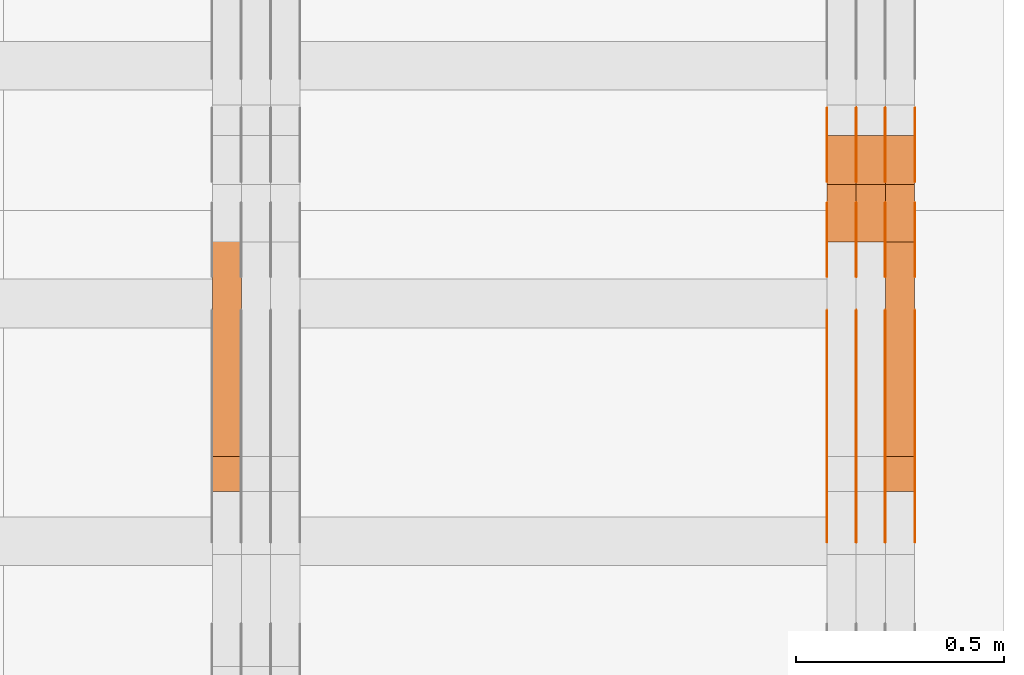
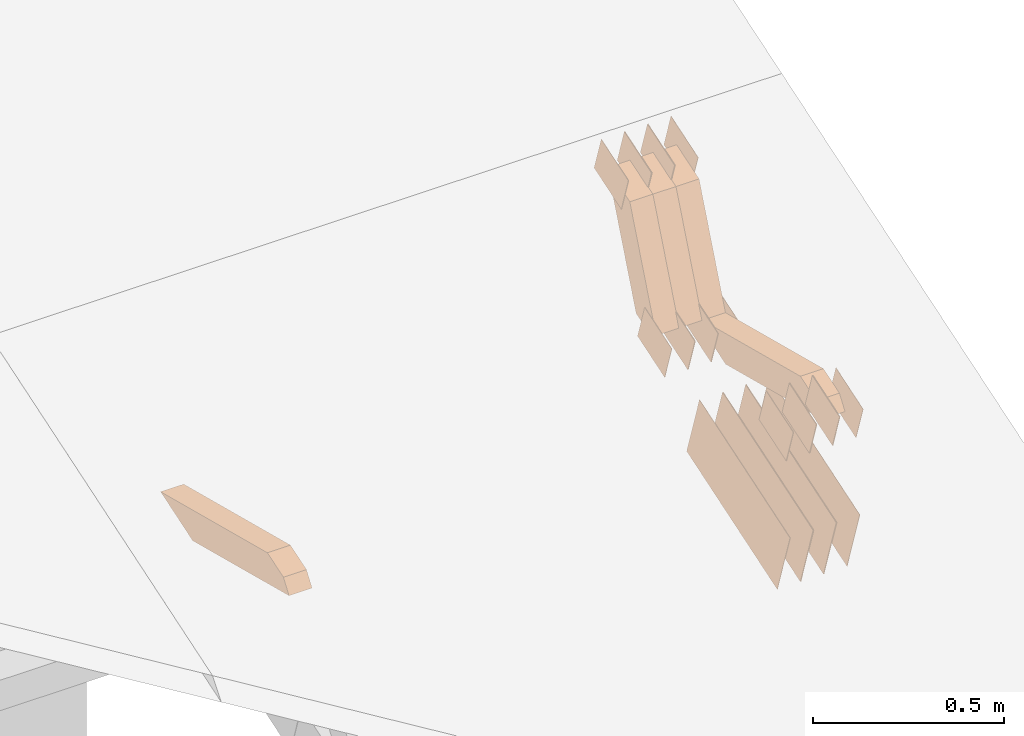
# One storey, part 315 of 385: 29 proxies.
"""IFC2X3 building model written with IfcOpenShell, lengths in millimetres."""

import ifcopenshell
import ifcopenshell.guid

model = None  # the IFC model being written
_history = None  # IfcOwnerHistory: only IFC2X3 demands one
_inside = {}  # id of a spatial element -> (the spatial element, [elements in it])
_under = {}  # id of a project, library or spatial element -> (it, [spatial elements below it])
_declared = {}  # id of a project -> (the project, [libraries it declares])
_typed = {}  # id of a type object -> (the type object, [elements of that type])
_made_of = {}  # id of a material, layer set ... -> (it, [elements and type objects made of it])


def new_model(schema):
    """Start an empty IFC model of exactly this schema.

    Asked for "IFC4X3", IfcOpenShell would pick the latest addendum, in which some entities
    have other attributes; the version numbers below select the first issue.
    IFC2X3 requires an IfcOwnerHistory on every rooted entity: one is made here for all.
    """
    global model, _history
    if schema == "IFC4X3":
        model = ifcopenshell.file(schema_version=(4, 3, 0, 0))
    else:
        model = ifcopenshell.file(schema=schema)
    _inside.clear()
    _under.clear()
    _declared.clear()
    _typed.clear()
    _made_of.clear()
    _history = None
    if model.schema == "IFC2X3":
        org = make("IfcOrganization", Name="unknown")
        user = make(
            "IfcPersonAndOrganization",
            ThePerson=make("IfcPerson", FamilyName="unknown"),
            TheOrganization=org,
        )
        app = make(
            "IfcApplication",
            ApplicationDeveloper=org,
            Version="unknown",
            ApplicationFullName="unknown",
            ApplicationIdentifier="unknown",
        )
        _history = make(
            "IfcOwnerHistory",
            OwningUser=user,
            OwningApplication=app,
            ChangeAction="ADDED",
            CreationDate=0,
        )
    return model


def make(cls, **values):
    """One entity of the class cls with the attributes given. An attribute that is None is left unset."""
    return model.create_entity(
        cls, **{name: value for name, value in values.items() if value is not None}
    )


def entity(cls, *values):
    """Any entity or typed value of the class cls, its attributes in the order of the schema. None: left unset."""
    e = model.create_entity(cls)
    for i, value in enumerate(values):
        if value is not None:
            e[i] = value
    return e


def rooted(cls, **values):
    """An entity with a GlobalId (a new one), such as an element, a storey or a relation."""
    return make(cls, GlobalId=ifcopenshell.guid.new(), OwnerHistory=_history, **values)


def si_unit(unit_type, name, prefix=None):
    """IfcSIUnit, for example si_unit("LENGTHUNIT", "METRE", prefix="MILLI")."""
    return make("IfcSIUnit", UnitType=unit_type, Prefix=prefix, Name=name)


def converted_unit(unit_type, name, factor, base, dimensions=None, offset=None):
    """IfcConversionBasedUnit, such as the inch: factor (a typed value) times the base unit."""
    return make(
        "IfcConversionBasedUnit"
        if offset is None
        else "IfcConversionBasedUnitWithOffset",
        ConversionOffset=offset,
        Dimensions=None
        if dimensions is None
        else entity("IfcDimensionalExponents", *dimensions),
        UnitType=unit_type,
        Name=name,
        ConversionFactor=make(
            "IfcMeasureWithUnit", ValueComponent=factor, UnitComponent=base
        ),
    )


def derived_unit(unit_type, elements):
    """IfcDerivedUnit: a product of units, each with its exponent."""
    return make(
        "IfcDerivedUnit",
        Elements=[
            make("IfcDerivedUnitElement", Unit=unit, Exponent=power)
            for unit, power in elements
        ],
        UnitType=unit_type,
    )


def assignment(units):
    """IfcUnitAssignment: the units of a project."""
    return None if units is None else make("IfcUnitAssignment", Units=units)


def point(xyz):
    """IfcCartesianPoint."""
    return None if xyz is None else make("IfcCartesianPoint", Coordinates=xyz)


def direction(xyz):
    """IfcDirection."""
    return None if xyz is None else make("IfcDirection", DirectionRatios=xyz)


def frame(location, z_axis=None, x_axis=None):
    """IfcAxis2Placement3D, a coordinate frame: its origin and axes. An axis left out is left unset."""
    return make(
        "IfcAxis2Placement3D",
        Location=point(location),
        Axis=direction(z_axis),
        RefDirection=direction(x_axis),
    )


def origin():
    """The frame at (0, 0, 0) with its axes left unset."""
    return frame((0.0, 0.0, 0.0))


def place(relative_to, where):
    """IfcLocalPlacement: puts the frame where relative to a parent placement (None: the world)."""
    return make(
        "IfcLocalPlacement", PlacementRelTo=relative_to, RelativePlacement=where
    )


def context(
    kind, dimensions, precision=None, world=None, true_north=None, identifier=None
):
    """IfcGeometricRepresentationContext, for example the 3D "Model" context."""
    return make(
        "IfcGeometricRepresentationContext",
        ContextIdentifier=identifier,
        ContextType=kind,
        CoordinateSpaceDimension=dimensions,
        Precision=precision,
        WorldCoordinateSystem=world,
        TrueNorth=true_north,
    )


def subcontext(parent, identifier, kind, view, scale=None):
    """IfcGeometricRepresentationSubContext, for example "Body" below "Model"."""
    return make(
        "IfcGeometricRepresentationSubContext",
        ContextIdentifier=identifier,
        ContextType=kind,
        ParentContext=parent,
        TargetScale=scale,
        TargetView=view,
    )


def project(units=None, contexts=None):
    """IfcProject with its units and contexts."""
    return rooted(
        "IfcProject",
        Name="project",
        RepresentationContexts=contexts,
        UnitsInContext=assignment(units),
    )


def spatial(cls, under=None, at=None, **own):
    """A site, building, storey or space (cls), placed at a placement, below another one or the project."""
    s = rooted(cls, ObjectPlacement=at, **own)
    if under is not None:
        _under.setdefault(under.id(), (under, []))[1].append(s)
    return s


def polyline(points):
    """IfcPolyline through the points."""
    return make("IfcPolyline", Points=[point(p) for p in points])


def outline(outer, holes=None, kind="AREA"):
    """IfcArbitraryClosedProfileDef: a profile drawn as a closed curve; with holes, ...WithVoids."""
    if holes is None:
        return make("IfcArbitraryClosedProfileDef", ProfileType=kind, OuterCurve=outer)
    return make(
        "IfcArbitraryProfileDefWithVoids",
        ProfileType=kind,
        OuterCurve=outer,
        InnerCurves=holes,
    )


def extrude(swept, where, along, depth):
    """IfcExtrudedAreaSolid: the profile swept, set in the frame where, extruded along a direction by depth."""
    return make(
        "IfcExtrudedAreaSolid",
        SweptArea=swept,
        Position=where,
        ExtrudedDirection=direction(along),
        Depth=depth,
    )


def shape(context_of_items, identifier, shape_type, items):
    """IfcShapeRepresentation: the items that make up one representation, for example the "Body"."""
    return make(
        "IfcShapeRepresentation",
        ContextOfItems=context_of_items,
        RepresentationIdentifier=identifier,
        RepresentationType=shape_type,
        Items=items,
    )


def source(mapping_origin, context_of_items, identifier, shape_type, items):
    """IfcRepresentationMap: a shape defined once, which mapped items show again and again."""
    return make(
        "IfcRepresentationMap",
        MappingOrigin=mapping_origin,
        MappedRepresentation=shape(context_of_items, identifier, shape_type, items),
    )


def transform(
    local_origin,
    x_axis=None,
    y_axis=None,
    z_axis=None,
    scale=None,
    scale2=None,
    scale3=None,
    uniform=True,
):
    """IfcCartesianTransformationOperator3D, or its non-uniform kind. x_axis, y_axis, z_axis: its Axis1, 2, 3."""
    if uniform:
        return make(
            "IfcCartesianTransformationOperator3D",
            Axis1=direction(x_axis),
            Axis2=direction(y_axis),
            LocalOrigin=point(local_origin),
            Scale=scale,
            Axis3=direction(z_axis),
        )
    return make(
        "IfcCartesianTransformationOperator3DnonUniform",
        Axis1=direction(x_axis),
        Axis2=direction(y_axis),
        LocalOrigin=point(local_origin),
        Scale=scale,
        Axis3=direction(z_axis),
        Scale2=scale2,
        Scale3=scale3,
    )


def mapped(mapping_source, mapping_target):
    """IfcMappedItem: shows the shape of a source again, moved by a transform."""
    return make(
        "IfcMappedItem", MappingSource=mapping_source, MappingTarget=mapping_target
    )


def material(Name=None, Category=None):
    """IfcMaterial."""
    return make("IfcMaterial", Name=Name, Category=Category)


def made_of(thing, what):
    """Note that an element or type object is made of a material, layer set ...; save() writes the relation."""
    if what is not None:
        _made_of.setdefault(what.id(), (what, []))[1].append(thing)
    return thing


def type_object(cls, material=None, **own):
    """A type object (cls), such as IfcWallType, which elements share."""
    return made_of(rooted(cls, **own), material)


def type_shapes(of_type, sources):
    """Give a type object the sources (RepresentationMaps) that its elements show as mapped items."""
    of_type.RepresentationMaps = sources


def element(
    cls,
    number,
    at=None,
    inside=None,
    cuts=None,
    type_object=None,
    material=None,
    context=None,
    identifier="Body",
    shape_type=None,
    held_by="IfcProductDefinitionShape",
    body=None,
    shapes=None,
    **own,
):
    """One element of the class cls, such as IfcWall. Its Tag is "e" and its number.

    at: its placement. inside: the storey or other place that contains it. cuts: it is an
    opening in that element (IfcRelVoidsElement). A single representation is given by context,
    identifier, shape_type and body (its items); several are given by shapes. held_by: the class
    of the entity that holds the representations. save() writes the other relations.
    """
    e = rooted(cls, Tag="e%d" % number, ObjectPlacement=at, **own)
    if body is not None:
        shapes = [shape(context, identifier, shape_type, body)]
    if shapes is not None:
        e.Representation = make(held_by, Representations=shapes)
    if inside is not None:
        _inside.setdefault(inside.id(), (inside, []))[1].append(e)
    if cuts is not None:
        rooted(
            "IfcRelVoidsElement", RelatingBuildingElement=cuts, RelatedOpeningElement=e
        )
    if type_object is not None:
        _typed.setdefault(type_object.id(), (type_object, []))[1].append(e)
    return made_of(e, material)


def aggregate(whole, parts):
    """IfcRelAggregates: a whole, such as a stair, and the parts it consists of."""
    return rooted("IfcRelAggregates", RelatingObject=whole, RelatedObjects=parts)


def save(model, path):
    """Write the relations noted so far, then the file.

    IfcRelAggregates (storeys below a building ...), IfcRelContainedInSpatialStructure (elements
    in a storey), IfcRelDefinesByType, IfcRelAssociatesMaterial and IfcRelDeclares: one each for
    every whole, place, type object, material and project.
    """
    for whole, parts in _under.values():
        aggregate(whole, parts)
    for where, things in _inside.values():
        rooted(
            "IfcRelContainedInSpatialStructure",
            RelatedElements=things,
            RelatingStructure=where,
        )
    for kind, things in _typed.values():
        rooted("IfcRelDefinesByType", RelatedObjects=things, RelatingType=kind)
    for what, things in _made_of.values():
        rooted("IfcRelAssociatesMaterial", RelatedObjects=things, RelatingMaterial=what)
    for by, libraries in _declared.values():
        rooted("IfcRelDeclares", RelatingContext=by, RelatedDefinitions=libraries)
    model.write(path)


model = new_model("IFC2X3")

# Units and contexts
model_context = context("Model", 3, precision=0.01, world=origin(), true_north=direction((6.12303176911189e-17, 1.0)))
body_context = subcontext(model_context, "Body", "Model", "MODEL_VIEW")
ifc_project = project(units=[si_unit("LENGTHUNIT", "METRE", prefix="MILLI"), si_unit("AREAUNIT", "SQUARE_METRE"), si_unit("VOLUMEUNIT", "CUBIC_METRE"), converted_unit("PLANEANGLEUNIT", "DEGREE", entity("IfcRatioMeasure", 0.0174532925199433), si_unit("PLANEANGLEUNIT", "RADIAN"), dimensions=[0, 0, 0, 0, 0, 0, 0]), si_unit("MASSUNIT", "GRAM", prefix="KILO"), derived_unit("MASSDENSITYUNIT", [(si_unit("MASSUNIT", "GRAM", prefix="KILO"), 1), (si_unit("LENGTHUNIT", "METRE"), -3)]), si_unit("TIMEUNIT", "SECOND"), si_unit("FREQUENCYUNIT", "HERTZ"), si_unit("THERMODYNAMICTEMPERATUREUNIT", "DEGREE_CELSIUS"), derived_unit("THERMALTRANSMITTANCEUNIT", [(si_unit("MASSUNIT", "GRAM", prefix="KILO"), 1), (si_unit("THERMODYNAMICTEMPERATUREUNIT", "KELVIN"), -1), (si_unit("TIMEUNIT", "SECOND"), -3)]), derived_unit("VOLUMETRICFLOWRATEUNIT", [(si_unit("LENGTHUNIT", "METRE"), 3), (si_unit("TIMEUNIT", "SECOND"), -1)]), si_unit("ELECTRICCURRENTUNIT", "AMPERE"), si_unit("ELECTRICVOLTAGEUNIT", "VOLT"), si_unit("POWERUNIT", "WATT"), si_unit("FORCEUNIT", "NEWTON", prefix="KILO"), si_unit("ILLUMINANCEUNIT", "LUX"), si_unit("LUMINOUSFLUXUNIT", "LUMEN"), si_unit("LUMINOUSINTENSITYUNIT", "CANDELA"), derived_unit("USERDEFINED", [(si_unit("MASSUNIT", "GRAM", prefix="KILO"), -1), (si_unit("LENGTHUNIT", "METRE"), -2), (si_unit("TIMEUNIT", "SECOND"), 3), (si_unit("LUMINOUSFLUXUNIT", "LUMEN"), 1)]), derived_unit("LINEARVELOCITYUNIT", [(si_unit("LENGTHUNIT", "METRE"), 1), (si_unit("TIMEUNIT", "SECOND"), -1)]), si_unit("PRESSUREUNIT", "PASCAL"), derived_unit("USERDEFINED", [(si_unit("LENGTHUNIT", "METRE"), -2), (si_unit("MASSUNIT", "GRAM", prefix="KILO"), 1), (si_unit("TIMEUNIT", "SECOND"), -2)])], contexts=[model_context])

# Site, building, storey
site_placement = place(None, origin())
site = spatial("IfcSite", under=ifc_project, at=site_placement, CompositionType="ELEMENT")
building_placement = place(site_placement, origin())
building = spatial("IfcBuilding", under=site, at=building_placement, CompositionType="ELEMENT")
storey_placement = place(building_placement, origin())
storey = spatial("IfcBuildingStorey", under=building, at=storey_placement, Name="Default", CompositionType="ELEMENT", Elevation=0.0)

# Proxies
ifc_material_1 = material(Name="IfcSurfaceStyle #626086")
building_element_proxy_type_1 = type_object("IfcBuildingElementProxyType", PredefinedType="NOTDEFINED", material=ifc_material_1)
shared_shape_1 = source(origin(), body_context, "Body", "SweptSolid", [
    extrude(outline(polyline([(-74.9998565677179, -60.000059685226), (74.9998794200128, -60.000059685226), (74.9998565677179, 60.000059685226), (-74.9998794200128, 60.000059685226), (-74.9998565677179, -60.000059685226)])), frame((75.0001976720505, 60.000059685226, 0.0), z_axis=(0.0, 0.0, 1.0), x_axis=(-1.0, 0.0, 0.0)), (0.0, 0.0, 1.0), 1.3),
])
type_shapes(building_element_proxy_type_1, [shared_shape_1])
proxy_1_placement = place(building_placement, frame((49861.3, 8537.53090236182, 1950.11166041942), z_axis=(-1.0, 0.0, 0.0), x_axis=(0.0, 0.951056516295124, 0.309016994375039)))
element("IfcBuildingElementProxy", 1, at=proxy_1_placement, inside=storey, type_object=building_element_proxy_type_1, material=ifc_material_1, context=body_context, shape_type="MappedRepresentation", body=[
    mapped(shared_shape_1, transform((0.0, 0.0, 0.0), scale=1.0)),
])
ifc_material_2 = material(Name="IfcSurfaceStyle #626029")
building_element_proxy_type_2 = type_object("IfcBuildingElementProxyType", PredefinedType="NOTDEFINED", material=ifc_material_2)
shared_shape_2 = source(origin(), body_context, "Body", "SweptSolid", [
    extrude(outline(polyline([(-74.9998565677179, -60.000059685226), (74.9998794200128, -60.000059685226), (74.9998565677179, 60.000059685226), (-74.9998794200128, 60.000059685226), (-74.9998565677179, -60.000059685226)])), frame((75.0001976720505, 60.000059685226, 0.0), z_axis=(0.0, 0.0, 1.0), x_axis=(-1.0, 0.0, 0.0)), (0.0, 0.0, 1.0), 1.3),
])
type_shapes(building_element_proxy_type_2, [shared_shape_2])
proxy_2_placement = place(building_placement, frame((49790.0, 8537.53090236182, 1950.11166041942), z_axis=(-1.0, 0.0, 0.0), x_axis=(0.0, 0.951056516295124, 0.309016994375039)))
element("IfcBuildingElementProxy", 2, at=proxy_2_placement, inside=storey, type_object=building_element_proxy_type_2, material=ifc_material_2, context=body_context, shape_type="MappedRepresentation", body=[
    mapped(shared_shape_2, transform((0.0, 0.0, 0.0), scale=1.0)),
])
ifc_material_3 = material(Name="IfcSurfaceStyle #625972")
building_element_proxy_type_3 = type_object("IfcBuildingElementProxyType", PredefinedType="NOTDEFINED", material=ifc_material_3)
shared_shape_3 = source(origin(), body_context, "Body", "SweptSolid", [
    extrude(outline(polyline([(-74.9998565677179, -60.000059685226), (74.9998794200128, -60.000059685226), (74.9998565677179, 60.000059685226), (-74.9998794200128, 60.000059685226), (-74.9998565677179, -60.000059685226)])), frame((75.0001976720505, 60.000059685226, 0.0), z_axis=(0.0, 0.0, 1.0), x_axis=(-1.0, 0.0, 0.0)), (0.0, 0.0, 1.0), 1.3),
])
type_shapes(building_element_proxy_type_3, [shared_shape_3])
proxy_3_placement = place(building_placement, frame((49791.3, 8537.53090236182, 1950.11166041942), z_axis=(-1.0, 0.0, 0.0), x_axis=(0.0, 0.951056516295124, 0.309016994375039)))
element("IfcBuildingElementProxy", 3, at=proxy_3_placement, inside=storey, type_object=building_element_proxy_type_3, material=ifc_material_3, context=body_context, shape_type="MappedRepresentation", body=[
    mapped(shared_shape_3, transform((0.0, 0.0, 0.0), scale=1.0)),
])
ifc_material_4 = material(Name="IfcSurfaceStyle #625915")
building_element_proxy_type_4 = type_object("IfcBuildingElementProxyType", PredefinedType="NOTDEFINED", material=ifc_material_4)
shared_shape_4 = source(origin(), body_context, "Body", "SweptSolid", [
    extrude(outline(polyline([(-74.9998565677179, -60.000059685226), (74.9998794200128, -60.000059685226), (74.9998565677179, 60.000059685226), (-74.9998794200128, 60.000059685226), (-74.9998565677179, -60.000059685226)])), frame((75.0001976720505, 60.000059685226, 0.0), z_axis=(0.0, 0.0, 1.0), x_axis=(-1.0, 0.0, 0.0)), (0.0, 0.0, 1.0), 1.29999999999999),
])
type_shapes(building_element_proxy_type_4, [shared_shape_4])
proxy_4_placement = place(building_placement, frame((49720.0, 8537.53090236182, 1950.11166041942), z_axis=(-1.0, 0.0, 0.0), x_axis=(0.0, 0.951056516295124, 0.309016994375039)))
element("IfcBuildingElementProxy", 4, at=proxy_4_placement, inside=storey, type_object=building_element_proxy_type_4, material=ifc_material_4, context=body_context, shape_type="MappedRepresentation", body=[
    mapped(shared_shape_4, transform((0.0, 0.0, 0.0), scale=1.0)),
])
ifc_material_5 = material(Name="IfcSurfaceStyle #625858")
building_element_proxy_type_5 = type_object("IfcBuildingElementProxyType", PredefinedType="NOTDEFINED", material=ifc_material_5)
shared_shape_5 = source(origin(), body_context, "Body", "SweptSolid", [
    extrude(outline(polyline([(-74.9998565677179, -60.000059685226), (74.9998794200128, -60.000059685226), (74.9998565677179, 60.000059685226), (-74.9998794200128, 60.000059685226), (-74.9998565677179, -60.000059685226)])), frame((75.0001976720505, 60.000059685226, 0.0), z_axis=(0.0, 0.0, 1.0), x_axis=(-1.0, 0.0, 0.0)), (0.0, 0.0, 1.0), 1.29999999999999),
])
type_shapes(building_element_proxy_type_5, [shared_shape_5])
proxy_5_placement = place(building_placement, frame((49721.3, 8537.53090236182, 1950.11166041942), z_axis=(-1.0, 0.0, 0.0), x_axis=(0.0, 0.951056516295124, 0.309016994375039)))
element("IfcBuildingElementProxy", 5, at=proxy_5_placement, inside=storey, type_object=building_element_proxy_type_5, material=ifc_material_5, context=body_context, shape_type="MappedRepresentation", body=[
    mapped(shared_shape_5, transform((0.0, 0.0, 0.0), scale=1.0)),
])
ifc_material_6 = material(Name="IfcSurfaceStyle #625801")
building_element_proxy_type_6 = type_object("IfcBuildingElementProxyType", PredefinedType="NOTDEFINED", material=ifc_material_6)
shared_shape_6 = source(origin(), body_context, "Body", "SweptSolid", [
    extrude(outline(polyline([(-74.9998565677179, -60.000059685226), (74.9998794200128, -60.000059685226), (74.9998565677179, 60.000059685226), (-74.9998794200128, 60.000059685226), (-74.9998565677179, -60.000059685226)])), frame((75.0001976720505, 60.000059685226, 0.0), z_axis=(0.0, 0.0, 1.0), x_axis=(-1.0, 0.0, 0.0)), (0.0, 0.0, 1.0), 1.29999999999999),
])
type_shapes(building_element_proxy_type_6, [shared_shape_6])
proxy_6_placement = place(building_placement, frame((49650.0, 8537.53090236182, 1950.11166041942), z_axis=(-1.0, 0.0, 0.0), x_axis=(0.0, 0.951056516295124, 0.309016994375039)))
element("IfcBuildingElementProxy", 6, at=proxy_6_placement, inside=storey, type_object=building_element_proxy_type_6, material=ifc_material_6, context=body_context, shape_type="MappedRepresentation", body=[
    mapped(shared_shape_6, transform((0.0, 0.0, 0.0), scale=1.0)),
])
ifc_material_7 = material(Name="IfcSurfaceStyle #625744")
building_element_proxy_type_7 = type_object("IfcBuildingElementProxyType", PredefinedType="NOTDEFINED", material=ifc_material_7)
shared_shape_7 = source(origin(), body_context, "Body", "SweptSolid", [
    extrude(outline(polyline([(-74.9998754286225, -60.0000016373515), (74.9998605591045, -60.0000016373515), (74.9998754286225, 60.0000016373515), (-74.9998605591045, 60.0000016373515), (-74.9998754286225, -60.0000016373515)])), frame((74.9998754286225, 60.0000016373515, 0.0), z_axis=(0.0, 0.0, 1.0), x_axis=(-1.0, 0.0, 0.0)), (0.0, 0.0, 1.0), 1.3),
])
type_shapes(building_element_proxy_type_7, [shared_shape_7])
proxy_7_placement = place(building_placement, frame((49861.3, 8765.47458614632, 2350.86432930304), z_axis=(-1.0, 0.0, 0.0), x_axis=(0.0, 0.951056516295154, 0.309016994374948)))
element("IfcBuildingElementProxy", 7, at=proxy_7_placement, inside=storey, type_object=building_element_proxy_type_7, material=ifc_material_7, context=body_context, shape_type="MappedRepresentation", body=[
    mapped(shared_shape_7, transform((0.0, 0.0, 0.0), scale=1.0)),
])
ifc_material_8 = material(Name="IfcSurfaceStyle #625687")
building_element_proxy_type_8 = type_object("IfcBuildingElementProxyType", PredefinedType="NOTDEFINED", material=ifc_material_8)
shared_shape_8 = source(origin(), body_context, "Body", "SweptSolid", [
    extrude(outline(polyline([(-74.9998754286225, -60.0000016373515), (74.9998605591045, -60.0000016373515), (74.9998754286225, 60.0000016373515), (-74.9998605591045, 60.0000016373515), (-74.9998754286225, -60.0000016373515)])), frame((74.9998754286225, 60.0000016373515, 0.0), z_axis=(0.0, 0.0, 1.0), x_axis=(-1.0, 0.0, 0.0)), (0.0, 0.0, 1.0), 1.3),
])
type_shapes(building_element_proxy_type_8, [shared_shape_8])
proxy_8_placement = place(building_placement, frame((49790.0, 8765.47458614632, 2350.86432930304), z_axis=(-1.0, 0.0, 0.0), x_axis=(0.0, 0.951056516295154, 0.309016994374948)))
element("IfcBuildingElementProxy", 8, at=proxy_8_placement, inside=storey, type_object=building_element_proxy_type_8, material=ifc_material_8, context=body_context, shape_type="MappedRepresentation", body=[
    mapped(shared_shape_8, transform((0.0, 0.0, 0.0), scale=1.0)),
])
ifc_material_9 = material(Name="IfcSurfaceStyle #625630")
building_element_proxy_type_9 = type_object("IfcBuildingElementProxyType", PredefinedType="NOTDEFINED", material=ifc_material_9)
shared_shape_9 = source(origin(), body_context, "Body", "SweptSolid", [
    extrude(outline(polyline([(-74.9998754286225, -60.0000016373515), (74.9998605591045, -60.0000016373515), (74.9998754286225, 60.0000016373515), (-74.9998605591045, 60.0000016373515), (-74.9998754286225, -60.0000016373515)])), frame((74.9998754286225, 60.0000016373515, 0.0), z_axis=(0.0, 0.0, 1.0), x_axis=(-1.0, 0.0, 0.0)), (0.0, 0.0, 1.0), 1.3),
])
type_shapes(building_element_proxy_type_9, [shared_shape_9])
proxy_9_placement = place(building_placement, frame((49791.3, 8765.47458614632, 2350.86432930304), z_axis=(-1.0, 0.0, 0.0), x_axis=(0.0, 0.951056516295154, 0.309016994374948)))
element("IfcBuildingElementProxy", 9, at=proxy_9_placement, inside=storey, type_object=building_element_proxy_type_9, material=ifc_material_9, context=body_context, shape_type="MappedRepresentation", body=[
    mapped(shared_shape_9, transform((0.0, 0.0, 0.0), scale=1.0)),
])
ifc_material_10 = material(Name="IfcSurfaceStyle #625573")
building_element_proxy_type_10 = type_object("IfcBuildingElementProxyType", PredefinedType="NOTDEFINED", material=ifc_material_10)
shared_shape_10 = source(origin(), body_context, "Body", "SweptSolid", [
    extrude(outline(polyline([(-74.9998754286225, -60.0000016373515), (74.9998605591045, -60.0000016373515), (74.9998754286225, 60.0000016373515), (-74.9998605591045, 60.0000016373515), (-74.9998754286225, -60.0000016373515)])), frame((74.9998754286225, 60.0000016373515, 0.0), z_axis=(0.0, 0.0, 1.0), x_axis=(-1.0, 0.0, 0.0)), (0.0, 0.0, 1.0), 1.29999999999999),
])
type_shapes(building_element_proxy_type_10, [shared_shape_10])
proxy_10_placement = place(building_placement, frame((49720.0, 8765.47458614632, 2350.86432930304), z_axis=(-1.0, 0.0, 0.0), x_axis=(0.0, 0.951056516295154, 0.309016994374948)))
element("IfcBuildingElementProxy", 10, at=proxy_10_placement, inside=storey, type_object=building_element_proxy_type_10, material=ifc_material_10, context=body_context, shape_type="MappedRepresentation", body=[
    mapped(shared_shape_10, transform((0.0, 0.0, 0.0), scale=1.0)),
])
ifc_material_11 = material(Name="IfcSurfaceStyle #625516")
building_element_proxy_type_11 = type_object("IfcBuildingElementProxyType", PredefinedType="NOTDEFINED", material=ifc_material_11)
shared_shape_11 = source(origin(), body_context, "Body", "SweptSolid", [
    extrude(outline(polyline([(-74.9998754286225, -60.0000016373515), (74.9998605591045, -60.0000016373515), (74.9998754286225, 60.0000016373515), (-74.9998605591045, 60.0000016373515), (-74.9998754286225, -60.0000016373515)])), frame((74.9998754286225, 60.0000016373515, 0.0), z_axis=(0.0, 0.0, 1.0), x_axis=(-1.0, 0.0, 0.0)), (0.0, 0.0, 1.0), 1.29999999999999),
])
type_shapes(building_element_proxy_type_11, [shared_shape_11])
proxy_11_placement = place(building_placement, frame((49721.3, 8765.47458614632, 2350.86432930304), z_axis=(-1.0, 0.0, 0.0), x_axis=(0.0, 0.951056516295154, 0.309016994374948)))
element("IfcBuildingElementProxy", 11, at=proxy_11_placement, inside=storey, type_object=building_element_proxy_type_11, material=ifc_material_11, context=body_context, shape_type="MappedRepresentation", body=[
    mapped(shared_shape_11, transform((0.0, 0.0, 0.0), scale=1.0)),
])
ifc_material_12 = material(Name="IfcSurfaceStyle #625459")
building_element_proxy_type_12 = type_object("IfcBuildingElementProxyType", PredefinedType="NOTDEFINED", material=ifc_material_12)
shared_shape_12 = source(origin(), body_context, "Body", "SweptSolid", [
    extrude(outline(polyline([(-74.9998754286225, -60.0000016373515), (74.9998605591045, -60.0000016373515), (74.9998754286225, 60.0000016373515), (-74.9998605591045, 60.0000016373515), (-74.9998754286225, -60.0000016373515)])), frame((74.9998754286225, 60.0000016373515, 0.0), z_axis=(0.0, 0.0, 1.0), x_axis=(-1.0, 0.0, 0.0)), (0.0, 0.0, 1.0), 1.29999999999999),
])
type_shapes(building_element_proxy_type_12, [shared_shape_12])
proxy_12_placement = place(building_placement, frame((49650.0, 8765.47458614632, 2350.86432930304), z_axis=(-1.0, 0.0, 0.0), x_axis=(0.0, 0.951056516295154, 0.309016994374948)))
element("IfcBuildingElementProxy", 12, at=proxy_12_placement, inside=storey, type_object=building_element_proxy_type_12, material=ifc_material_12, context=body_context, shape_type="MappedRepresentation", body=[
    mapped(shared_shape_12, transform((0.0, 0.0, 0.0), scale=1.0)),
])
ifc_material_13 = material(Name="IfcSurfaceStyle #625060")
building_element_proxy_type_13 = type_object("IfcBuildingElementProxyType", PredefinedType="NOTDEFINED", material=ifc_material_13)
shared_shape_13 = source(origin(), body_context, "Body", "SweptSolid", [
    extrude(outline(polyline([(-249.999749056184, -108.000229288163), (249.999396050782, -108.000229288163), (249.999749056184, 108.000229288163), (-249.999396050782, 108.000229288163), (-249.999749056184, -108.000229288163)])), frame((249.999841104007, 108.000229288163, 0.0), z_axis=(0.0, 0.0, 1.0), x_axis=(-1.0, 0.0, 0.0)), (0.0, 0.0, 1.0), 1.29999999999998),
])
type_shapes(building_element_proxy_type_13, [shared_shape_13])
proxy_13_placement = place(building_placement, frame((49861.3, 7917.13457673635, 1720.66532252899), z_axis=(-1.0, 0.0, 0.0), x_axis=(0.0, 0.951056516295124, 0.309016994375039)))
element("IfcBuildingElementProxy", 13, at=proxy_13_placement, inside=storey, type_object=building_element_proxy_type_13, material=ifc_material_13, context=body_context, shape_type="MappedRepresentation", body=[
    mapped(shared_shape_13, transform((0.0, 0.0, 0.0), scale=1.0)),
])
ifc_material_14 = material(Name="IfcSurfaceStyle #625003")
building_element_proxy_type_14 = type_object("IfcBuildingElementProxyType", PredefinedType="NOTDEFINED", material=ifc_material_14)
shared_shape_14 = source(origin(), body_context, "Body", "SweptSolid", [
    extrude(outline(polyline([(-249.999749056184, -108.000229288163), (249.999396050782, -108.000229288163), (249.999749056184, 108.000229288163), (-249.999396050782, 108.000229288163), (-249.999749056184, -108.000229288163)])), frame((249.999841104007, 108.000229288163, 0.0), z_axis=(0.0, 0.0, 1.0), x_axis=(-1.0, 0.0, 0.0)), (0.0, 0.0, 1.0), 1.29999999999998),
])
type_shapes(building_element_proxy_type_14, [shared_shape_14])
proxy_14_placement = place(building_placement, frame((49790.0, 7917.13457673635, 1720.66532252899), z_axis=(-1.0, 0.0, 0.0), x_axis=(0.0, 0.951056516295124, 0.309016994375039)))
element("IfcBuildingElementProxy", 14, at=proxy_14_placement, inside=storey, type_object=building_element_proxy_type_14, material=ifc_material_14, context=body_context, shape_type="MappedRepresentation", body=[
    mapped(shared_shape_14, transform((0.0, 0.0, 0.0), scale=1.0)),
])
ifc_material_15 = material(Name="IfcSurfaceStyle #624946")
building_element_proxy_type_15 = type_object("IfcBuildingElementProxyType", PredefinedType="NOTDEFINED", material=ifc_material_15)
shared_shape_15 = source(origin(), body_context, "Body", "SweptSolid", [
    extrude(outline(polyline([(-249.999749056184, -108.000229288163), (249.999396050782, -108.000229288163), (249.999749056184, 108.000229288163), (-249.999396050782, 108.000229288163), (-249.999749056184, -108.000229288163)])), frame((249.999841104007, 108.000229288163, 0.0), z_axis=(0.0, 0.0, 1.0), x_axis=(-1.0, 0.0, 0.0)), (0.0, 0.0, 1.0), 1.29999999999998),
])
type_shapes(building_element_proxy_type_15, [shared_shape_15])
proxy_15_placement = place(building_placement, frame((49791.3, 7917.13457673635, 1720.66532252899), z_axis=(-1.0, 0.0, 0.0), x_axis=(0.0, 0.951056516295124, 0.309016994375039)))
element("IfcBuildingElementProxy", 15, at=proxy_15_placement, inside=storey, type_object=building_element_proxy_type_15, material=ifc_material_15, context=body_context, shape_type="MappedRepresentation", body=[
    mapped(shared_shape_15, transform((0.0, 0.0, 0.0), scale=1.0)),
])
ifc_material_16 = material(Name="IfcSurfaceStyle #624889")
building_element_proxy_type_16 = type_object("IfcBuildingElementProxyType", PredefinedType="NOTDEFINED", material=ifc_material_16)
shared_shape_16 = source(origin(), body_context, "Body", "SweptSolid", [
    extrude(outline(polyline([(-249.999749056184, -108.000229288163), (249.999396050782, -108.000229288163), (249.999749056184, 108.000229288163), (-249.999396050782, 108.000229288163), (-249.999749056184, -108.000229288163)])), frame((249.999841104007, 108.000229288163, 0.0), z_axis=(0.0, 0.0, 1.0), x_axis=(-1.0, 0.0, 0.0)), (0.0, 0.0, 1.0), 1.29999999999997),
])
type_shapes(building_element_proxy_type_16, [shared_shape_16])
proxy_16_placement = place(building_placement, frame((49720.0, 7917.13457673635, 1720.66532252899), z_axis=(-1.0, 0.0, 0.0), x_axis=(0.0, 0.951056516295124, 0.309016994375039)))
element("IfcBuildingElementProxy", 16, at=proxy_16_placement, inside=storey, type_object=building_element_proxy_type_16, material=ifc_material_16, context=body_context, shape_type="MappedRepresentation", body=[
    mapped(shared_shape_16, transform((0.0, 0.0, 0.0), scale=1.0)),
])
ifc_material_17 = material(Name="IfcSurfaceStyle #624832")
building_element_proxy_type_17 = type_object("IfcBuildingElementProxyType", PredefinedType="NOTDEFINED", material=ifc_material_17)
shared_shape_17 = source(origin(), body_context, "Body", "SweptSolid", [
    extrude(outline(polyline([(-249.999749056184, -108.000229288163), (249.999396050782, -108.000229288163), (249.999749056184, 108.000229288163), (-249.999396050782, 108.000229288163), (-249.999749056184, -108.000229288163)])), frame((249.999841104007, 108.000229288163, 0.0), z_axis=(0.0, 0.0, 1.0), x_axis=(-1.0, 0.0, 0.0)), (0.0, 0.0, 1.0), 1.29999999999997),
])
type_shapes(building_element_proxy_type_17, [shared_shape_17])
proxy_17_placement = place(building_placement, frame((49721.3, 7917.13457673635, 1720.66532252899), z_axis=(-1.0, 0.0, 0.0), x_axis=(0.0, 0.951056516295124, 0.309016994375039)))
element("IfcBuildingElementProxy", 17, at=proxy_17_placement, inside=storey, type_object=building_element_proxy_type_17, material=ifc_material_17, context=body_context, shape_type="MappedRepresentation", body=[
    mapped(shared_shape_17, transform((0.0, 0.0, 0.0), scale=1.0)),
])
ifc_material_18 = material(Name="IfcSurfaceStyle #624775")
building_element_proxy_type_18 = type_object("IfcBuildingElementProxyType", PredefinedType="NOTDEFINED", material=ifc_material_18)
shared_shape_18 = source(origin(), body_context, "Body", "SweptSolid", [
    extrude(outline(polyline([(-249.999749056184, -108.000229288163), (249.999396050782, -108.000229288163), (249.999749056184, 108.000229288163), (-249.999396050782, 108.000229288163), (-249.999749056184, -108.000229288163)])), frame((249.999841104007, 108.000229288163, 0.0), z_axis=(0.0, 0.0, 1.0), x_axis=(-1.0, 0.0, 0.0)), (0.0, 0.0, 1.0), 1.29999999999997),
])
type_shapes(building_element_proxy_type_18, [shared_shape_18])
proxy_18_placement = place(building_placement, frame((49650.0, 7917.13457673635, 1720.66532252899), z_axis=(-1.0, 0.0, 0.0), x_axis=(0.0, 0.951056516295124, 0.309016994375039)))
element("IfcBuildingElementProxy", 18, at=proxy_18_placement, inside=storey, type_object=building_element_proxy_type_18, material=ifc_material_18, context=body_context, shape_type="MappedRepresentation", body=[
    mapped(shared_shape_18, transform((0.0, 0.0, 0.0), scale=1.0)),
])
ifc_material_19 = material(Name="IfcSurfaceStyle #611380")
building_element_proxy_type_19 = type_object("IfcBuildingElementProxyType", PredefinedType="NOTDEFINED", material=ifc_material_19)
shared_shape_19 = source(origin(), body_context, "Body", "SweptSolid", [
    extrude(outline(polyline([(-74.9998754286253, -60.0000016373506), (74.9998605591091, -60.0000016373506), (74.9998754286234, 60.0000016373506), (-74.9998605591072, 60.0000016373506), (-74.9998754286253, -60.0000016373506)])), frame((75.0007355357002, 60.0002637031812, 0.0), z_axis=(0.0, 0.0, 1.0), x_axis=(-1.0, 0.0, 0.0)), (0.0, 0.0, 1.0), 1.3),
])
type_shapes(building_element_proxy_type_19, [shared_shape_19])
proxy_19_placement = place(building_placement, frame((49861.3, 7899.79204652808, 2069.58672486412), z_axis=(-1.0, 0.0, 0.0), x_axis=(0.0, 0.951056516295154, 0.309016994374948)))
element("IfcBuildingElementProxy", 19, at=proxy_19_placement, inside=storey, type_object=building_element_proxy_type_19, material=ifc_material_19, context=body_context, shape_type="MappedRepresentation", body=[
    mapped(shared_shape_19, transform((0.0, 0.0, 0.0), scale=1.0)),
])
ifc_material_20 = material(Name="IfcSurfaceStyle #611323")
building_element_proxy_type_20 = type_object("IfcBuildingElementProxyType", PredefinedType="NOTDEFINED", material=ifc_material_20)
shared_shape_20 = source(origin(), body_context, "Body", "SweptSolid", [
    extrude(outline(polyline([(-74.9998754286253, -60.0000016373506), (74.9998605591091, -60.0000016373506), (74.9998754286234, 60.0000016373506), (-74.9998605591072, 60.0000016373506), (-74.9998754286253, -60.0000016373506)])), frame((75.0007355357002, 60.0002637031812, 0.0), z_axis=(0.0, 0.0, 1.0), x_axis=(-1.0, 0.0, 0.0)), (0.0, 0.0, 1.0), 1.3),
])
type_shapes(building_element_proxy_type_20, [shared_shape_20])
proxy_20_placement = place(building_placement, frame((49790.0, 7899.79204652808, 2069.58672486412), z_axis=(-1.0, 0.0, 0.0), x_axis=(0.0, 0.951056516295154, 0.309016994374948)))
element("IfcBuildingElementProxy", 20, at=proxy_20_placement, inside=storey, type_object=building_element_proxy_type_20, material=ifc_material_20, context=body_context, shape_type="MappedRepresentation", body=[
    mapped(shared_shape_20, transform((0.0, 0.0, 0.0), scale=1.0)),
])
ifc_material_21 = material(Name="IfcSurfaceStyle #611266")
building_element_proxy_type_21 = type_object("IfcBuildingElementProxyType", PredefinedType="NOTDEFINED", material=ifc_material_21)
shared_shape_21 = source(origin(), body_context, "Body", "SweptSolid", [
    extrude(outline(polyline([(-74.9998754286253, -60.0000016373506), (74.9998605591091, -60.0000016373506), (74.9998754286234, 60.0000016373506), (-74.9998605591072, 60.0000016373506), (-74.9998754286253, -60.0000016373506)])), frame((75.0007355357002, 60.0002637031812, 0.0), z_axis=(0.0, 0.0, 1.0), x_axis=(-1.0, 0.0, 0.0)), (0.0, 0.0, 1.0), 1.3),
])
type_shapes(building_element_proxy_type_21, [shared_shape_21])
proxy_21_placement = place(building_placement, frame((49791.3, 7899.79204652808, 2069.58672486412), z_axis=(-1.0, 0.0, 0.0), x_axis=(0.0, 0.951056516295154, 0.309016994374948)))
element("IfcBuildingElementProxy", 21, at=proxy_21_placement, inside=storey, type_object=building_element_proxy_type_21, material=ifc_material_21, context=body_context, shape_type="MappedRepresentation", body=[
    mapped(shared_shape_21, transform((0.0, 0.0, 0.0), scale=1.0)),
])
ifc_material_22 = material(Name="IfcSurfaceStyle #611209")
building_element_proxy_type_22 = type_object("IfcBuildingElementProxyType", PredefinedType="NOTDEFINED", material=ifc_material_22)
shared_shape_22 = source(origin(), body_context, "Body", "SweptSolid", [
    extrude(outline(polyline([(-74.9998754286253, -60.0000016373506), (74.9998605591091, -60.0000016373506), (74.9998754286234, 60.0000016373506), (-74.9998605591072, 60.0000016373506), (-74.9998754286253, -60.0000016373506)])), frame((75.0007355357002, 60.0002637031812, 0.0), z_axis=(0.0, 0.0, 1.0), x_axis=(-1.0, 0.0, 0.0)), (0.0, 0.0, 1.0), 1.29999999999999),
])
type_shapes(building_element_proxy_type_22, [shared_shape_22])
proxy_22_placement = place(building_placement, frame((49720.0, 7899.79204652808, 2069.58672486412), z_axis=(-1.0, 0.0, 0.0), x_axis=(0.0, 0.951056516295154, 0.309016994374948)))
element("IfcBuildingElementProxy", 22, at=proxy_22_placement, inside=storey, type_object=building_element_proxy_type_22, material=ifc_material_22, context=body_context, shape_type="MappedRepresentation", body=[
    mapped(shared_shape_22, transform((0.0, 0.0, 0.0), scale=1.0)),
])
ifc_material_23 = material(Name="IfcSurfaceStyle #611152")
building_element_proxy_type_23 = type_object("IfcBuildingElementProxyType", PredefinedType="NOTDEFINED", material=ifc_material_23)
shared_shape_23 = source(origin(), body_context, "Body", "SweptSolid", [
    extrude(outline(polyline([(-74.9998754286253, -60.0000016373506), (74.9998605591091, -60.0000016373506), (74.9998754286234, 60.0000016373506), (-74.9998605591072, 60.0000016373506), (-74.9998754286253, -60.0000016373506)])), frame((75.0007355357002, 60.0002637031812, 0.0), z_axis=(0.0, 0.0, 1.0), x_axis=(-1.0, 0.0, 0.0)), (0.0, 0.0, 1.0), 1.29999999999999),
])
type_shapes(building_element_proxy_type_23, [shared_shape_23])
proxy_23_placement = place(building_placement, frame((49721.3, 7899.79204652808, 2069.58672486412), z_axis=(-1.0, 0.0, 0.0), x_axis=(0.0, 0.951056516295154, 0.309016994374948)))
element("IfcBuildingElementProxy", 23, at=proxy_23_placement, inside=storey, type_object=building_element_proxy_type_23, material=ifc_material_23, context=body_context, shape_type="MappedRepresentation", body=[
    mapped(shared_shape_23, transform((0.0, 0.0, 0.0), scale=1.0)),
])
ifc_material_24 = material(Name="IfcSurfaceStyle #611095")
building_element_proxy_type_24 = type_object("IfcBuildingElementProxyType", PredefinedType="NOTDEFINED", material=ifc_material_24)
shared_shape_24 = source(origin(), body_context, "Body", "SweptSolid", [
    extrude(outline(polyline([(-74.9998754286253, -60.0000016373506), (74.9998605591091, -60.0000016373506), (74.9998754286234, 60.0000016373506), (-74.9998605591072, 60.0000016373506), (-74.9998754286253, -60.0000016373506)])), frame((75.0007355357002, 60.0002637031812, 0.0), z_axis=(0.0, 0.0, 1.0), x_axis=(-1.0, 0.0, 0.0)), (0.0, 0.0, 1.0), 1.29999999999999),
])
type_shapes(building_element_proxy_type_24, [shared_shape_24])
proxy_24_placement = place(building_placement, frame((49650.0, 7899.79204652808, 2069.58672486412), z_axis=(-1.0, 0.0, 0.0), x_axis=(0.0, 0.951056516295154, 0.309016994374948)))
element("IfcBuildingElementProxy", 24, at=proxy_24_placement, inside=storey, type_object=building_element_proxy_type_24, material=ifc_material_24, context=body_context, shape_type="MappedRepresentation", body=[
    mapped(shared_shape_24, transform((0.0, 0.0, 0.0), scale=1.0)),
])
ifc_material_25 = material(Name="IfcSurfaceStyle #598996")
building_element_proxy_type_25 = type_object("IfcBuildingElementProxyType", Name="T2-W45 598994", PredefinedType="NOTDEFINED", material=ifc_material_25)
shared_shape_25 = source(origin(), body_context, "Body", "SweptSolid", [
    extrude(outline(polyline([(-275.953018340717, -47.500197738425), (128.971267956636, -47.5001977384251), (168.669977842085, -0.000132525443043008), (174.867371111815, 47.5002640011466), (-196.55559856982, 47.5002640011466), (-275.953018340717, -47.500197738425)])), frame((174.867371111815, 47.5002640011466, 0.0), z_axis=(0.0, 0.0, 1.0), x_axis=(-1.0, 0.0, 0.0)), (0.0, 0.0, 1.0), 70.0),
])
type_shapes(building_element_proxy_type_25, [shared_shape_25])
proxy_25_placement = place(building_placement, frame((49860.0, 8621.494140625, 1941.33422851563), z_axis=(-1.0, 0.0, 0.0), x_axis=(0.0, 0.372787901688292, 0.927916580493549)))
element("IfcBuildingElementProxy", 25, at=proxy_25_placement, inside=storey, type_object=building_element_proxy_type_25, material=ifc_material_25, Name="T2-W45", context=body_context, shape_type="MappedRepresentation", body=[
    mapped(shared_shape_25, transform((0.0, 0.0, 0.0), scale=1.0)),
])
ifc_material_26 = material(Name="IfcSurfaceStyle #598930")
building_element_proxy_type_26 = type_object("IfcBuildingElementProxyType", Name="T2-W45 598928", PredefinedType="NOTDEFINED", material=ifc_material_26)
shared_shape_26 = source(origin(), body_context, "Body", "SweptSolid", [
    extrude(outline(polyline([(-275.953018340717, -47.500197738425), (128.971267956636, -47.5001977384251), (168.669977842085, -0.000132525443043008), (174.867371111815, 47.5002640011466), (-196.55559856982, 47.5002640011466), (-275.953018340717, -47.500197738425)])), frame((174.867371111815, 47.5002640011466, 0.0), z_axis=(0.0, 0.0, 1.0), x_axis=(-1.0, 0.0, 0.0)), (0.0, 0.0, 1.0), 70.0),
])
type_shapes(building_element_proxy_type_26, [shared_shape_26])
proxy_26_placement = place(building_placement, frame((49790.0, 8621.494140625, 1941.33422851563), z_axis=(-1.0, 0.0, 0.0), x_axis=(0.0, 0.372787901688292, 0.927916580493549)))
element("IfcBuildingElementProxy", 26, at=proxy_26_placement, inside=storey, type_object=building_element_proxy_type_26, material=ifc_material_26, Name="T2-W45", context=body_context, shape_type="MappedRepresentation", body=[
    mapped(shared_shape_26, transform((0.0, 0.0, 0.0), scale=1.0)),
])
ifc_material_27 = material(Name="IfcSurfaceStyle #598864")
building_element_proxy_type_27 = type_object("IfcBuildingElementProxyType", Name="T2-W45 598862", PredefinedType="NOTDEFINED", material=ifc_material_27)
shared_shape_27 = source(origin(), body_context, "Body", "SweptSolid", [
    extrude(outline(polyline([(-275.953018340717, -47.500197738425), (128.971267956636, -47.5001977384251), (168.669977842085, -0.000132525443043008), (174.867371111815, 47.5002640011466), (-196.55559856982, 47.5002640011466), (-275.953018340717, -47.500197738425)])), frame((174.867371111815, 47.5002640011466, 0.0), z_axis=(0.0, 0.0, 1.0), x_axis=(-1.0, 0.0, 0.0)), (0.0, 0.0, 1.0), 70.0),
])
type_shapes(building_element_proxy_type_27, [shared_shape_27])
proxy_27_placement = place(building_placement, frame((49720.0, 8621.494140625, 1941.33422851563), z_axis=(-1.0, 0.0, 0.0), x_axis=(0.0, 0.372787901688292, 0.927916580493549)))
element("IfcBuildingElementProxy", 27, at=proxy_27_placement, inside=storey, type_object=building_element_proxy_type_27, material=ifc_material_27, Name="T2-W45", context=body_context, shape_type="MappedRepresentation", body=[
    mapped(shared_shape_27, transform((0.0, 0.0, 0.0), scale=1.0)),
])
ifc_material_28 = material(Name="IfcSurfaceStyle #598600")
building_element_proxy_type_28 = type_object("IfcBuildingElementProxyType", Name="T2-W11 598598", PredefinedType="NOTDEFINED", material=ifc_material_28)
shared_shape_28 = source(origin(), body_context, "Body", "SweptSolid", [
    extrude(outline(polyline([(-261.366417792209, -47.5000378467523), (260.949520182121, -47.5000378467523), (242.928845159301, -7.41559889341215e-06), (168.237407166939, 47.5000415545517), (-410.749354716152, 47.5000415545517), (-261.366417792209, -47.5000378467523)])), frame((260.949520182121, 47.5000415545517, 0.0), z_axis=(0.0, 0.0, 1.0), x_axis=(-1.0, 0.0, 0.0)), (0.0, 0.0, 1.0), 70.0),
])
type_shapes(building_element_proxy_type_28, [shared_shape_28])
proxy_28_placement = place(building_placement, frame((49860.0, 8017.44318793234, 2097.03832883996), z_axis=(-1.0, 0.0, 0.0), x_axis=(0.0, 0.968347201599873, -0.249607085543851)))
element("IfcBuildingElementProxy", 28, at=proxy_28_placement, inside=storey, type_object=building_element_proxy_type_28, material=ifc_material_28, Name="T2-W11", context=body_context, shape_type="MappedRepresentation", body=[
    mapped(shared_shape_28, transform((0.0, 0.0, 0.0), scale=1.0)),
])
ifc_material_29 = material(Name="IfcSurfaceStyle #564036")
building_element_proxy_type_29 = type_object("IfcBuildingElementProxyType", Name="T1-W11 564034", PredefinedType="NOTDEFINED", material=ifc_material_29)
shared_shape_29 = source(origin(), body_context, "Body", "SweptSolid", [
    extrude(outline(polyline([(-261.366417792209, -47.5000378467523), (260.949520182121, -47.5000378467523), (242.928845159301, -7.41559889341215e-06), (168.237407166939, 47.5000415545517), (-410.749354716152, 47.5000415545517), (-261.366417792209, -47.5000378467523)])), frame((260.949520182121, 47.5000415545517, 0.0), z_axis=(0.0, 0.0, 1.0), x_axis=(-1.0, 0.0, 0.0)), (0.0, 0.0, 1.0), 70.0),
])
type_shapes(building_element_proxy_type_29, [shared_shape_29])
proxy_29_placement = place(building_placement, frame((48245.0, 8017.44318793235, 2097.03832883996), z_axis=(-1.0, 0.0, 0.0), x_axis=(0.0, 0.968347201599873, -0.249607085543851)))
element("IfcBuildingElementProxy", 29, at=proxy_29_placement, inside=storey, type_object=building_element_proxy_type_29, material=ifc_material_29, Name="T1-W11", context=body_context, shape_type="MappedRepresentation", body=[
    mapped(shared_shape_29, transform((0.0, 0.0, 0.0), scale=1.0)),
])

save(model, "model.ifc")
